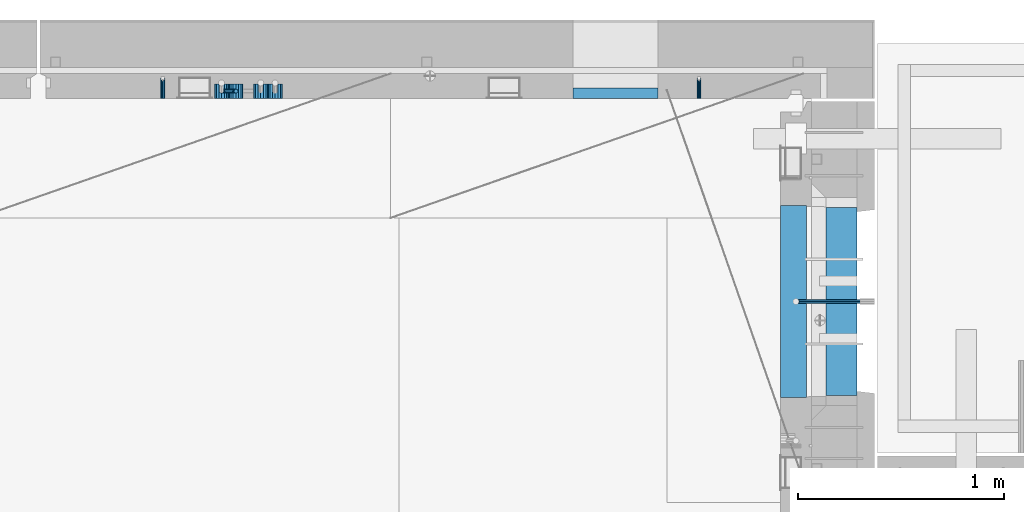
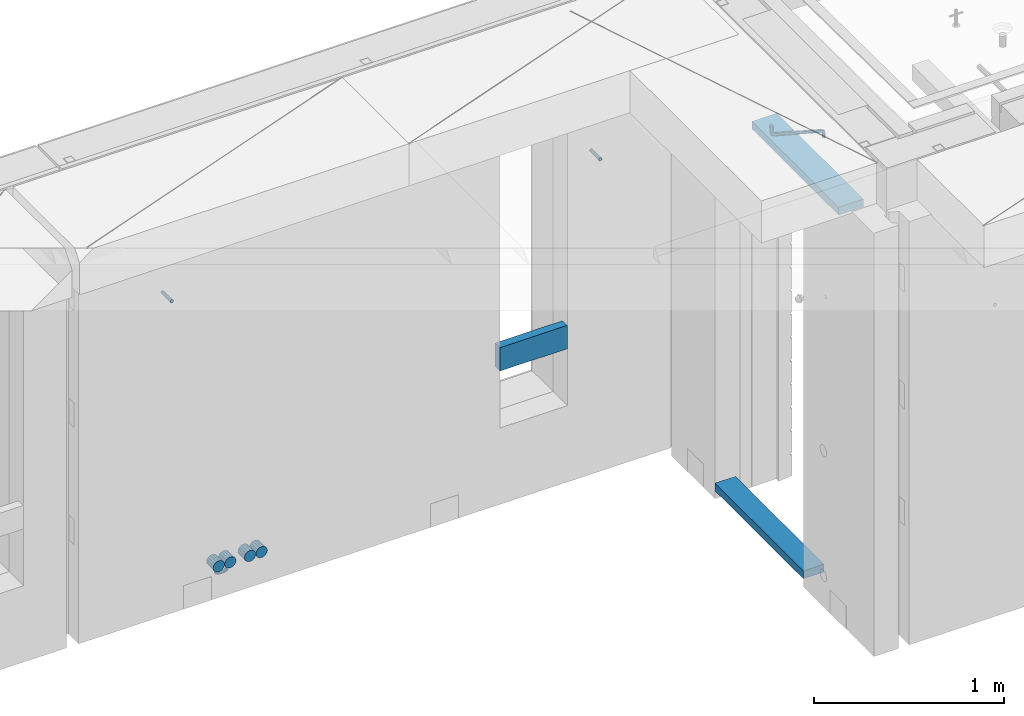
# One storey, part 159 of 334: 11 beams, 4 elements without a shape of their own.
"""IFC2X3 building model written with IfcOpenShell, lengths in millimetres."""

from ifc_helpers import new_model, si_unit, frame, origin_with_axes, place, context, subcontext, project, spatial, faceted_brep, material, type_object, element, aggregate, save


model = new_model("IFC2X3")

# Units and contexts
model_context = context("Model", 3, precision=1e-05, world=origin_with_axes())
body_context = subcontext(model_context, "Body", "Model", "MODEL_VIEW")
ifc_project = project(units=[si_unit("LENGTHUNIT", "METRE", prefix="MILLI"), si_unit("AREAUNIT", "SQUARE_METRE"), si_unit("VOLUMEUNIT", "CUBIC_METRE"), si_unit("MASSUNIT", "GRAM", prefix="KILO"), si_unit("TIMEUNIT", "SECOND"), si_unit("PLANEANGLEUNIT", "RADIAN"), si_unit("SOLIDANGLEUNIT", "STERADIAN"), si_unit("THERMODYNAMICTEMPERATUREUNIT", "DEGREE_CELSIUS"), si_unit("LUMINOUSINTENSITYUNIT", "LUMEN")], contexts=[model_context])

# Site, building, storey
site_placement = place(None, origin_with_axes())
site = spatial("IfcSite", under=ifc_project, at=site_placement, CompositionType="ELEMENT")
building_placement = place(site_placement, origin_with_axes())
building = spatial("IfcBuilding", under=site, at=building_placement, CompositionType="ELEMENT")
storey_placement = place(building_placement, origin_with_axes())
storey = spatial("IfcBuildingStorey", under=building, at=storey_placement, Name="3", CompositionType="ELEMENT", Elevation=0.0)

# Assembly, beam
assembly_1_placement = place(storey_placement, origin_with_axes())
assembly_1 = element("IfcElementAssembly", 1, at=assembly_1_placement, inside=storey, AssemblyPlace="NOTDEFINED", PredefinedType="REINFORCEMENT_UNIT")
ifc_material_1 = material(Name="TIMBER")
beam_type_1 = type_object("IfcBeamType", Name="50X150", PredefinedType="NOTDEFINED")
beam_1_placement = place(assembly_1_placement, frame((31604.9951872276, 21180.0002716511, 90080.0), z_axis=(0.0, 0.0, -1.0), x_axis=(0.0, 1.0, 0.0)))
beam_1 = element("IfcBeam", 2, at=beam_1_placement, type_object=beam_type_1, material=ifc_material_1, ObjectType="50X150", context=body_context, shape_type="Brep", body=[
    faceted_brep([(0.0, 75.0, -25.0), (1.81898940354586e-12, 75.0, 25.0), (909.999618530273, 75.0, 25.0), (909.999618530273, 75.0, -25.0), (1.81898940354586e-12, -75.0000000000009, 25.0), (909.999618530273, -75.0, 25.0), (0.0, -75.0, -25.0), (909.999618530273, -75.0, -25.0)], [[[0, 1, 2, 3]], [[1, 4, 5, 2]], [[4, 6, 7, 5]], [[6, 0, 3, 7]], [[5, 7, 3, 2]], [[6, 4, 1, 0]]]),
])

# Assemblies, beams
assembly_2_placement = place(storey_placement, origin_with_axes())
assembly_2 = element("IfcElementAssembly", 3, at=assembly_2_placement, inside=storey, AssemblyPlace="NOTDEFINED", PredefinedType="REINFORCEMENT_UNIT")
assembly_3_placement = place(assembly_2_placement, origin_with_axes())
assembly_3 = element("IfcElementAssembly", 4, at=assembly_3_placement, Name="Steel Assembly", AssemblyPlace="NOTDEFINED", PredefinedType="RIGID_FRAME")
ifc_material_2 = material(Name="STEEL/Steel_Undefined")
beam_type_2 = type_object("IfcBeamType", PredefinedType="NOTDEFINED")
beam_2_placement = place(assembly_3_placement, frame((30914.9996121022, 22620.0, 89755.0), z_axis=(1.0, 0.0, 0.0), x_axis=(0.0, 1.0, 0.0)))
beam_2 = element("IfcBeam", 5, at=beam_2_placement, type_object=beam_type_2, material=ifc_material_2, Name="M16", context=body_context, shape_type="Brep", body=[
    faceted_brep([(0.0, -8.49999999999272, -1.45519152283669e-11), (0.0, -7.36121593215648, 4.24999999998545), (100.000000000262, -7.36121593215648, 4.24999999998545), (100.000000000262, -8.49999999999272, -1.45519152283669e-11), (0.0, -4.24999999998545, 7.36121593216376), (100.000000000262, -4.24999999998545, 7.36121593216376), (0.0, 1.45519152283669e-11, 8.49999999998545), (100.000000000262, 1.45519152283669e-11, 8.49999999998545), (0.0, 4.25000000001455, 7.36121593216376), (100.000000000262, 4.25000000001455, 7.36121593216376), (0.0, 7.36121593217104, 4.24999999998545), (100.000000000262, 7.36121593217104, 4.24999999998545), (0.0, 8.50000000000728, 0.0), (100.000000000262, 8.50000000000728, 0.0), (0.0, 7.36121593217104, -4.25000000001455), (100.000000000262, 7.36121593217104, -4.25000000001455), (0.0, 4.25000000000728, -7.36121593219286), (100.000000000262, 4.25000000000728, -7.36121593219286), (0.0, 7.27595761418343e-12, -8.5), (100.000000000262, 7.27595761418343e-12, -8.5), (0.0, -4.24999999999272, -7.36121593217831), (100.000000000262, -4.24999999999272, -7.36121593217831), (0.0, -7.36121593215648, -4.25), (100.000000000262, -7.36121593215648, -4.25), (0.0, -10.4999999999927, -1.45519152283669e-11), (0.0, -9.09326673972828, -5.25000000001455), (100.000000000262, -9.09326673972828, -5.25000000001455), (100.000000000262, -10.4999999999927, -1.45519152283669e-11), (0.0, -5.24999999998545, -9.09326673974283), (100.000000000262, -5.24999999998545, -9.09326673974283), (0.0, 7.27595761418343e-12, -10.5), (100.000000000262, 7.27595761418343e-12, -10.5), (0.0, 5.25000000001455, -9.09326673975738), (100.000000000262, 5.25000000001455, -9.09326673975738), (0.0, 9.09326673975011, -5.25000000001455), (100.000000000262, 9.09326673975011, -5.25000000001455), (0.0, 10.5000000000073, -1.45519152283669e-11), (100.000000000262, 10.5000000000073, -1.45519152283669e-11), (0.0, 9.09326673975011, 5.25), (100.000000000262, 9.09326673975011, 5.25), (0.0, 5.25000000000728, 9.09326673972828), (100.000000000262, 5.25000000000728, 9.09326673972828), (0.0, 1.45519152283669e-11, 10.4999999999854), (100.000000000262, 1.45519152283669e-11, 10.4999999999854), (0.0, -5.24999999999272, 9.09326673972828), (100.000000000262, -5.24999999999272, 9.09326673972828), (0.0, -9.09326673972828, 5.24999999998545), (100.000000000262, -9.09326673972828, 5.24999999998545)], [[[0, 1, 2, 3]], [[1, 4, 5, 2]], [[4, 6, 7, 5]], [[6, 8, 9, 7]], [[8, 10, 11, 9]], [[10, 12, 13, 11]], [[12, 14, 15, 13]], [[14, 16, 17, 15]], [[16, 18, 19, 17]], [[18, 20, 21, 19]], [[20, 22, 23, 21]], [[22, 0, 3, 23]], [[24, 25, 26, 27]], [[25, 28, 29, 26]], [[28, 30, 31, 29]], [[30, 32, 33, 31]], [[32, 34, 35, 33]], [[34, 36, 37, 35]], [[36, 38, 39, 37]], [[38, 40, 41, 39]], [[40, 42, 43, 41]], [[42, 44, 45, 43]], [[44, 46, 47, 45]], [[46, 24, 27, 47]], [[29, 31, 33, 35, 37, 39, 41, 43, 45, 47, 27, 26], [5, 7, 9, 11, 13, 15, 17, 19, 21, 23, 3, 2]], [[46, 44, 42, 40, 38, 36, 34, 32, 30, 28, 25, 24], [22, 20, 18, 16, 14, 12, 10, 8, 6, 4, 1, 0]]]),
])
aggregate(assembly_3, [beam_2])
assembly_4_placement = place(assembly_2_placement, origin_with_axes())
assembly_4 = element("IfcElementAssembly", 6, at=assembly_4_placement, Name="Steel Assembly", AssemblyPlace="NOTDEFINED", PredefinedType="RIGID_FRAME")
beam_3_placement = place(assembly_4_placement, frame((28314.9960018609, 22620.0, 89755.0), z_axis=(-1.0, 3.00000001838171e-08, 0.0), x_axis=(0.0, 1.0, 0.0)))
beam_3 = element("IfcBeam", 7, at=beam_3_placement, type_object=beam_type_2, material=ifc_material_2, Name="M16", context=body_context, shape_type="Brep", body=[
    faceted_brep([(0.0, -8.49999999999272, -1.45519152283669e-11), (0.0, -7.36121593215648, 4.24999999998545), (100.000000000262, -7.36121593215648, 4.24999999998545), (100.000000000262, -8.49999999999272, -1.45519152283669e-11), (0.0, -4.24999999998545, 7.36121593216376), (100.000000000262, -4.24999999998545, 7.36121593216376), (0.0, 1.45519152283669e-11, 8.49999999998545), (100.000000000262, 1.45519152283669e-11, 8.49999999998545), (0.0, 4.25000000001455, 7.36121593216376), (100.000000000262, 4.25000000001455, 7.36121593216376), (0.0, 7.36121593217104, 4.24999999998545), (100.000000000262, 7.36121593217104, 4.24999999998545), (0.0, 8.50000000000728, 0.0), (100.000000000262, 8.50000000000728, 0.0), (0.0, 7.36121593217104, -4.25000000001455), (100.000000000262, 7.36121593217104, -4.25000000001455), (0.0, 4.25000000000728, -7.36121593219286), (100.000000000262, 4.25000000000728, -7.36121593219286), (0.0, 7.27595761418343e-12, -8.5), (100.000000000262, 7.27595761418343e-12, -8.5), (0.0, -4.24999999999272, -7.36121593217831), (100.000000000262, -4.24999999999272, -7.36121593217831), (0.0, -7.36121593215648, -4.25), (100.000000000262, -7.36121593215648, -4.25), (0.0, -10.4999999999927, -1.45519152283669e-11), (0.0, -9.09326673972828, -5.25000000001455), (100.000000000262, -9.09326673972828, -5.25000000001455), (100.000000000262, -10.4999999999927, -1.45519152283669e-11), (0.0, -5.24999999998545, -9.09326673974283), (100.000000000262, -5.24999999998545, -9.09326673974283), (0.0, 7.27595761418343e-12, -10.5), (100.000000000262, 7.27595761418343e-12, -10.5), (0.0, 5.25000000001455, -9.09326673975738), (100.000000000262, 5.25000000001455, -9.09326673975738), (0.0, 9.09326673975011, -5.25000000001455), (100.000000000262, 9.09326673975011, -5.25000000001455), (0.0, 10.5000000000073, -1.45519152283669e-11), (100.000000000262, 10.5000000000073, -1.45519152283669e-11), (0.0, 9.09326673975011, 5.25), (100.000000000262, 9.09326673975011, 5.25), (0.0, 5.25000000000728, 9.09326673972828), (100.000000000262, 5.25000000000728, 9.09326673972828), (0.0, 1.45519152283669e-11, 10.4999999999854), (100.000000000262, 1.45519152283669e-11, 10.4999999999854), (0.0, -5.24999999999272, 9.09326673972828), (100.000000000262, -5.24999999999272, 9.09326673972828), (0.0, -9.09326673972828, 5.24999999998545), (100.000000000262, -9.09326673972828, 5.24999999998545)], [[[0, 1, 2, 3]], [[1, 4, 5, 2]], [[4, 6, 7, 5]], [[6, 8, 9, 7]], [[8, 10, 11, 9]], [[10, 12, 13, 11]], [[12, 14, 15, 13]], [[14, 16, 17, 15]], [[16, 18, 19, 17]], [[18, 20, 21, 19]], [[20, 22, 23, 21]], [[22, 0, 3, 23]], [[24, 25, 26, 27]], [[25, 28, 29, 26]], [[28, 30, 31, 29]], [[30, 32, 33, 31]], [[32, 34, 35, 33]], [[34, 36, 37, 35]], [[36, 38, 39, 37]], [[38, 40, 41, 39]], [[40, 42, 43, 41]], [[42, 44, 45, 43]], [[44, 46, 47, 45]], [[46, 24, 27, 47]], [[29, 31, 33, 35, 37, 39, 41, 43, 45, 47, 27, 26], [5, 7, 9, 11, 13, 15, 17, 19, 21, 23, 3, 2]], [[46, 44, 42, 40, 38, 36, 34, 32, 30, 28, 25, 24], [22, 20, 18, 16, 14, 12, 10, 8, 6, 4, 1, 0]]]),
])
aggregate(assembly_4, [beam_3])

# Beam
ifc_material_3 = material()
beam_type_3 = type_object("IfcBeamType", Name="D20", PredefinedType="NOTDEFINED")
beam_4_placement = place(assembly_1_placement, frame((31702.0651872276, 21635.0000000039, 90220.28), z_axis=(-0.999209485784166, -0.00020572799995638, -0.0397537569914116), x_axis=(-0.0397537569985676, 6.39999925638301e-08, 0.999209506962626)))
beam_4 = element("IfcBeam", 8, at=beam_4_placement, type_object=beam_type_3, material=ifc_material_3, Name="JM20", ObjectType="D20", context=body_context, shape_type="Brep", body=[
    faceted_brep([(0.0, -10.0, 0.0), (-4.19531716033816e-08, -7.07106781186667, -7.07106781187031), (26.3851730625611, -7.07106780271351, -7.07106779974674), (26.3851730660535, -9.99999999077045, 1.18243406177498e-08), (0.0, 0.0, -10.0), (26.3851730589668, 9.14587872102857e-09, -9.99999998788189), (4.196772351861e-08, 7.07106781186303, -7.07106781186667), (26.3851730576571, 7.07106782101255, -7.0710677997472), (0.0, 10.0, 0.0), (26.3851730593888, 10.0000000091495, 1.21176526590716e-08), (4.196772351861e-08, 7.07106781185939, 7.07106781185939), (26.3851730631723, 7.07106782101619, 7.07106782398387), (0.0, 0.0, 10.0), (26.3851730667375, 9.15315467864275e-09, 10.0000000121181), (-4.19531716033816e-08, -7.07106781187031, 7.07106781185939), (26.3851730680617, -7.07106780271351, 7.07106782398296), (38.6387990555377, 0.00053833780111745, -7.38336449283906), (37.4430586178205, -7.07058200552274, -4.70977034770021), (34.5550974405633, -9.99964106806146, 1.74460312923975), (31.6666440137633, -7.07083577596131, 8.19887149183023), (30.4697151806322, 0.000179452214069897, 10.8722118684241), (31.6654556183639, 7.07129979554884, 8.19861772327886), (34.5534167956066, 10.0003588580803, 1.74424424634026), (37.4418702223775, 7.07155356597286, -4.71002411625204), (46.5698109210789, 7.07292605872499, 1.96124086770624), (48.7548734831362, 0.00205940803425619, 0.0100898832683924), (41.2967727296491, 10.0013728005906, 6.67270684289633), (36.0246331664675, 7.07195524891722, 11.3845749391899), (33.8417400848848, 0.000686475628754124, 13.3366967298962), (36.0268026468402, -7.07018017507653, 11.385545745416), (41.2998408382991, -9.99862691692761, 6.67407977023777), (46.5719804015243, -7.06920936526149, 1.96221167398289), (52.1766955363273, 7.07494587836845, 11.77897587077), (54.9687243336812, 0.00429788071051007, 10.8906314292522), (45.4389138642146, 10.0028649622, 13.9256551011317), (38.7022804405424, 7.07291984242329, 16.0731735411446), (35.9130237601494, 0.00143263318750542, 16.9635440140905), (38.7050525575032, -7.06921536447044, 16.0751995724927), (45.4428342298197, -9.99713444846202, 13.9285203429881), (52.1794676532882, -7.06718932852891, 11.7810019021831), (142.166420299589, -7.00909836739083, 294.143799597011), (135.429786872017, -9.93904348683645, 296.291318034092), (144.955676979953, 0.0623888418631395, 293.253429124143), (142.163648182657, 7.13303683951744, 294.141773565681), (135.425866510661, 10.0609559233271, 296.288452795829), (128.689233087061, 7.13101080351771, 298.435971235634), (125.899976406712, 0.0595235942673753, 299.326341708503), (128.692005203993, -7.01112440339057, 298.437997266966), (147.068569920637, 0.0631443010061048, 296.926548661886), (144.897857494318, -7.00812174957537, 298.892215917644), (139.655137467547, -9.93753272500544, 303.636800386314), (134.411524128242, -7.00907940566321, 308.380988833921), (132.238655054738, 0.0617899707685865, 310.345700010335), (134.409367481101, 7.13305602133914, 308.38003275464), (139.652087507944, 10.0624669967765, 303.63544828606), (144.895700847192, 7.13401367743427, 298.891259838389), (149.349355837621, 7.13466950711154, 302.082919188319), (150.512901837996, 0.0636515012993186, 299.394888529177), (146.541460642286, 10.0634815017911, 308.572636332), (143.734043175544, 7.13442914049301, 315.062451673432), (142.571650514263, 0.0633115715718304, 317.750719402909), (143.735196514695, -7.0077064342513, 315.062688743805), (146.543091710148, -9.93651842893087, 308.572971600169), (149.350509176773, -7.0074660676255, 302.083156258706), (154.724909358454, 7.13488656737172, 303.143653317829), (154.670204234542, 0.063819369621342, 300.215230568659), (154.856921558763, 10.0638172729959, 310.213489346082), (154.988909878753, 7.13488360238989, 317.283324591871), (155.043557350815, 0.0638151764978829, 320.211745451903), (154.988852227005, -7.00725202125614, 317.28332270274), (154.856840031658, -9.93618272723688, 310.213486674455), (154.724851706691, -7.00724905626703, 303.143651428684), (199.544700311235, -7.00743165723543, 302.30682413155), (199.676688632229, -9.93636532781238, 309.37665937721), (199.490052838737, 0.0636367686238373, 299.378403271518), (199.544757962984, 7.13470396637786, 302.306826020583), (199.676770164122, 10.0636346720203, 309.376662048705), (199.808758485131, 7.13470100144696, 316.446497294365), (199.863405957614, 0.0636325755804137, 319.374918154397), (199.808700833368, -7.00743462216269, 316.446495405334)], [[[0, 1, 2, 3]], [[1, 4, 5, 2]], [[4, 6, 7, 5]], [[6, 8, 9, 7]], [[8, 10, 11, 9]], [[10, 12, 13, 11]], [[12, 14, 15, 13]], [[14, 0, 3, 15]], [[14, 12, 10, 8, 6, 4, 1, 0]], [[2, 5, 16, 17]], [[3, 2, 17, 18]], [[15, 3, 18, 19]], [[13, 15, 19, 20]], [[11, 13, 20, 21]], [[9, 11, 21, 22]], [[7, 9, 22, 23]], [[5, 7, 23, 16]], [[23, 24, 25, 16]], [[22, 26, 24, 23]], [[21, 27, 26, 22]], [[20, 28, 27, 21]], [[19, 29, 28, 20]], [[18, 30, 29, 19]], [[17, 31, 30, 18]], [[16, 25, 31, 17]], [[24, 32, 33, 25]], [[26, 34, 32, 24]], [[27, 35, 34, 26]], [[28, 36, 35, 27]], [[29, 37, 36, 28]], [[30, 38, 37, 29]], [[31, 39, 38, 30]], [[25, 33, 39, 31]], [[38, 39, 40, 41]], [[39, 33, 42, 40]], [[33, 32, 43, 42]], [[32, 34, 44, 43]], [[34, 35, 45, 44]], [[35, 36, 46, 45]], [[36, 37, 47, 46]], [[37, 38, 41, 47]], [[40, 42, 48, 49]], [[41, 40, 49, 50]], [[47, 41, 50, 51]], [[46, 47, 51, 52]], [[45, 46, 52, 53]], [[44, 45, 53, 54]], [[43, 44, 54, 55]], [[42, 43, 55, 48]], [[55, 56, 57, 48]], [[54, 58, 56, 55]], [[53, 59, 58, 54]], [[52, 60, 59, 53]], [[51, 61, 60, 52]], [[50, 62, 61, 51]], [[49, 63, 62, 50]], [[48, 57, 63, 49]], [[56, 64, 65, 57]], [[58, 66, 64, 56]], [[59, 67, 66, 58]], [[60, 68, 67, 59]], [[61, 69, 68, 60]], [[62, 70, 69, 61]], [[63, 71, 70, 62]], [[57, 65, 71, 63]], [[70, 71, 72, 73]], [[71, 65, 74, 72]], [[65, 64, 75, 74]], [[64, 66, 76, 75]], [[66, 67, 77, 76]], [[67, 68, 78, 77]], [[68, 69, 79, 78]], [[69, 70, 73, 79]], [[74, 75, 76, 77, 78, 79, 73, 72]]]),
])

beam_5_placement = place(assembly_2_placement, frame((28600.0, 22655.0000005921, 87920.0), z_axis=(0.000207344999896057, 0.999999978504025, 0.0), x_axis=(0.0, 0.0, -1.0)))
beam_5 = element("IfcBeam", 9, at=beam_5_placement, type_object=beam_type_3, material=ifc_material_3, Name="JM20", ObjectType="D20", context=body_context, shape_type="Brep", body=[
    faceted_brep([(0.0, -10.0, 0.0), (-4.19531716033816e-08, -7.07106781186667, -7.07106781187031), (15.0, -7.07106781186303, -7.07106781186303), (15.0, -10.0, 0.0), (0.0, 0.0, -10.0), (15.0, 0.0, -10.0), (4.196772351861e-08, 7.07106781186303, -7.07106781186667), (15.0, 7.07106781186303, -7.07106781186303), (0.0, 10.0, 0.0), (15.0, 10.0, 0.0), (4.196772351861e-08, 7.07106781185939, 7.07106781185939), (15.0, 7.07106781186303, 7.07106781186303), (0.0, 0.0, 10.0), (15.0, 0.0, 10.0), (-4.19531716033816e-08, -7.07106781187031, 7.07106781185939), (15.0, -7.07106781186303, 7.07106781186303), (26.4805029249983, 7.71638602031089, -4.48664359282702e-05), (25.3600699192612, 5.00995527536361, -7.07100705464109), (22.6542637537787, -1.5230460533603, -9.99968429821456), (19.9481089831243, -8.05567439054357, -7.07049718768394), (18.826834370062, -10.7612046541835, 0.00067619437322719), (19.9472673757409, -8.05477390922533, 7.07163838257111), (22.6530735411652, -1.52177258047232, 10.0003156261519), (25.3592283118487, 5.01085575670004, 7.07112851561396), (34.1416172347817, -0.856916444474336, 7.07197867868672), (36.213203398147, 1.21320358659068, 0.000785173426265828), (29.141402548732, -5.85652387542723, 10.0012144823486), (24.1416172883619, -10.8569164797627, 7.07258597800683), (22.0710678501491, -12.9289320870121, 0.00164402434893418), (24.1426540134416, -10.8588120558743, -7.06954948090424), (29.1428686994623, -5.8592046249214, -9.99878528456611), (34.1426539599051, -0.858812020647747, -7.07015678022435), (40.0100668298401, -9.63902468957167, 7.07343309580028), (42.7163859636639, -8.51949674357456, 0.00228483768296428), (33.4771117462369, -12.3444560058379, 10.0025597629719), (26.9444371984719, -15.0509857193756, 7.07382216348924), (24.2387953379803, -16.1731654308933, 0.00283506249979837), (26.9451144717314, -15.0536374847834, -7.0683131956248), (33.47806955532, -12.3482061684881, -9.99743986281101), (40.0107441031432, -9.64167645503403, -7.06870226332103), (42.0710678126343, -19.9985334195844, 7.07521456002723), (45.0000000007858, -19.9999995702492, 0.00414690004981821), (35.0000000006694, -19.9979261199842, 10.0041466852272), (27.9289321887481, -19.9985334194498, 7.07521455996903), (25.0, -19.9999995700782, 0.00414690009347396), (27.928932188719, -20.0014657206229, -7.06692075997853), (35.0000000006548, -20.0020730201395, -9.99585288517846), (42.0710678125906, -20.001465720783, -7.0669207599276), (27.928932188137, -50.001465075733, -7.06070040962368), (24.9999999998254, -49.9999989249554, 0.010367250208219), (35.0, -50.0020723751913, -9.98963253479451), (42.071067811863, -50.001465075733, -7.06070040962368), (45.0, -49.999998925141, 0.0103672502445988), (42.071067811863, -49.9985327745489, 7.08143491011288), (35.0, -49.9979254750906, 10.010367035291), (27.928932188137, -49.9985327745489, 7.08143491011288), (42.7163859754073, -61.4805016490391, 0.0127476751804352), (40.0104054746334, -60.3611140008325, -7.05855238820368), (33.4775906501454, -57.6557408577646, -9.98804558495613), (26.944775825672, -54.9491531157582, -7.05967453130143), (24.2387953248981, -53.8268331663385, 0.0111607251892565), (26.9447758256429, -54.9462208145851, 7.08246078858792), (33.4775906501163, -57.6515939576748, 10.0119539853549), (40.0104054746189, -60.3581816996521, 7.08358293168567), (34.1421356237697, -69.1406679865104, 7.08540393637668), (36.213203435691, -71.213201904422, 0.014765702006116), (29.1421356236242, -64.1400607945761, 10.0132993365623), (24.1421356235078, -59.1406682015404, 7.0833304863263), (22.0710678116011, -57.071066584791, 0.011833400807518), (24.1421356235223, -59.1436005027172, -7.05880483355577), (29.1421356236242, -64.1442076946769, -9.98670023374871), (34.1421356237552, -69.1436002877017, -7.05673138350539), (25.3596491481148, -75.008937711249, 7.08662069281127), (26.4805029710988, -77.7163843043891, 0.0161141044009128), (22.6536686472245, -68.475515727856, 10.014198271514), (19.9476881463488, -61.943308343376, 7.08391159978055), (18.8268343233794, -59.2387940514018, 0.0122828682870022), (19.9476881463343, -61.94624064456, -7.05822372010152), (22.6536686471809, -68.4796626279458, -9.98580129879701), (25.3596491480712, -75.0118700124258, -7.05551462707081), (15.0000000001164, -77.0696000043099, 7.08704796086386), (15.0000000001746, -79.9999982800764, 0.0165876003811718), (14.9999999999418, -69.9979250449542, 10.0145139355009), (14.9999999997963, -62.9274646845297, 7.08411565970164), (15.0, -59.9999987101801, 0.0124407002949738), (14.9999999997672, -62.9303969856919, -7.05801966018043), (14.9999999998836, -70.0020719450404, -9.98548563481017), (15.0000000000582, -77.0725323054685, -7.05508735901822), (0.0, -62.9303969859466, -7.05801966011495), (0.0, -59.9999987101801, 0.0124407002949738), (0.0, -70.0020719452732, -9.98548563470104), (0.0, -77.0725323056759, -7.0550873589309), (0.0, -79.9999982802619, 0.0165876003884478), (0.0, -77.0696000044954, 7.08704796080565), (0.0, -69.9979250451725, 10.0145139353845), (0.0, -62.9274646847625, 7.0841156596216)], [[[0, 1, 2, 3]], [[1, 4, 5, 2]], [[4, 6, 7, 5]], [[6, 8, 9, 7]], [[8, 10, 11, 9]], [[10, 12, 13, 11]], [[12, 14, 15, 13]], [[14, 0, 3, 15]], [[14, 12, 10, 8, 6, 4, 1, 0]], [[7, 9, 16, 17]], [[5, 7, 17, 18]], [[2, 5, 18, 19]], [[3, 2, 19, 20]], [[15, 3, 20, 21]], [[13, 15, 21, 22]], [[11, 13, 22, 23]], [[9, 11, 23, 16]], [[23, 24, 25, 16]], [[22, 26, 24, 23]], [[21, 27, 26, 22]], [[20, 28, 27, 21]], [[19, 29, 28, 20]], [[18, 30, 29, 19]], [[17, 31, 30, 18]], [[16, 25, 31, 17]], [[24, 32, 33, 25]], [[26, 34, 32, 24]], [[27, 35, 34, 26]], [[28, 36, 35, 27]], [[29, 37, 36, 28]], [[30, 38, 37, 29]], [[31, 39, 38, 30]], [[25, 33, 39, 31]], [[32, 40, 41, 33]], [[34, 42, 40, 32]], [[35, 43, 42, 34]], [[36, 44, 43, 35]], [[37, 45, 44, 36]], [[38, 46, 45, 37]], [[39, 47, 46, 38]], [[33, 41, 47, 39]], [[44, 45, 48, 49]], [[45, 46, 50, 48]], [[46, 47, 51, 50]], [[47, 41, 52, 51]], [[41, 40, 53, 52]], [[40, 42, 54, 53]], [[42, 43, 55, 54]], [[43, 44, 49, 55]], [[51, 52, 56, 57]], [[50, 51, 57, 58]], [[48, 50, 58, 59]], [[49, 48, 59, 60]], [[55, 49, 60, 61]], [[54, 55, 61, 62]], [[53, 54, 62, 63]], [[52, 53, 63, 56]], [[63, 64, 65, 56]], [[62, 66, 64, 63]], [[61, 67, 66, 62]], [[60, 68, 67, 61]], [[59, 69, 68, 60]], [[58, 70, 69, 59]], [[57, 71, 70, 58]], [[56, 65, 71, 57]], [[64, 72, 73, 65]], [[66, 74, 72, 64]], [[67, 75, 74, 66]], [[68, 76, 75, 67]], [[69, 77, 76, 68]], [[70, 78, 77, 69]], [[71, 79, 78, 70]], [[65, 73, 79, 71]], [[72, 80, 81, 73]], [[74, 82, 80, 72]], [[75, 83, 82, 74]], [[76, 84, 83, 75]], [[77, 85, 84, 76]], [[78, 86, 85, 77]], [[79, 87, 86, 78]], [[73, 81, 87, 79]], [[84, 85, 88, 89]], [[85, 86, 90, 88]], [[86, 87, 91, 90]], [[87, 81, 92, 91]], [[81, 80, 93, 92]], [[80, 82, 94, 93]], [[82, 83, 95, 94]], [[83, 84, 89, 95]], [[90, 91, 92, 93, 94, 95, 89, 88]]]),
])

beam_type_4 = type_object("IfcBeamType", Name="D70", PredefinedType="NOTDEFINED")
beam_6_placement = place(assembly_2_placement, frame((28600.0, 22619.9999977209, 87955.0), z_axis=(0.0, 0.0, 1.0), x_axis=(0.0, 1.0, 0.0)))
beam_6 = element("IfcBeam", 10, at=beam_6_placement, type_object=beam_type_4, material=ifc_material_3, ObjectType="D70", context=body_context, shape_type="Brep", body=[
    faceted_brep([(0.0, -35.0, 0.0), (0.0, -32.3357836378964, -13.3939201327739), (70.0, -32.3357836378964, -13.3939201327739), (70.0, -35.0, 0.0), (0.0, -24.7487373415279, -24.7487373415352), (70.0, -24.7487373415279, -24.7487373415352), (0.0, -13.3939201327776, -32.3357836379), (70.0, -13.3939201327776, -32.3357836379), (0.0, 0.0, -35.0), (70.0, 0.0, -35.0), (0.0, 13.3939201327776, -32.3357836379), (70.0, 13.3939201327776, -32.3357836379), (0.0, 24.7487373415279, -24.7487373415352), (70.0, 24.7487373415279, -24.7487373415352), (0.0, 32.3357836378964, -13.3939201327739), (70.0, 32.3357836378964, -13.3939201327739), (0.0, 35.0, 0.0), (70.0, 35.0, 0.0), (0.0, 32.3357836378964, 13.3939201327739), (70.0, 32.3357836378964, 13.3939201327739), (0.0, 24.7487373415279, 24.7487373415352), (70.0, 24.7487373415279, 24.7487373415352), (0.0, 13.3939201327776, 32.3357836379), (70.0, 13.3939201327776, 32.3357836379), (0.0, 0.0, 35.0), (70.0, 0.0, 35.0), (0.0, -13.3939201327776, 32.3357836379), (70.0, -13.3939201327776, 32.3357836379), (0.0, -24.7487373415279, 24.7487373415352), (70.0, -24.7487373415279, 24.7487373415352), (0.0, -32.3357836378964, 13.3939201327739), (70.0, -32.3357836378964, 13.3939201327739)], [[[0, 1, 2, 3]], [[1, 4, 5, 2]], [[4, 6, 7, 5]], [[6, 8, 9, 7]], [[8, 10, 11, 9]], [[10, 12, 13, 11]], [[12, 14, 15, 13]], [[14, 16, 17, 15]], [[16, 18, 19, 17]], [[18, 20, 21, 19]], [[20, 22, 23, 21]], [[22, 24, 25, 23]], [[24, 26, 27, 25]], [[26, 28, 29, 27]], [[28, 30, 31, 29]], [[30, 0, 3, 31]], [[5, 7, 9, 11, 13, 15, 17, 19, 21, 23, 25, 27, 29, 31, 3, 2]], [[30, 28, 26, 24, 22, 20, 18, 16, 14, 12, 10, 8, 6, 4, 1, 0]]]),
])

beam_7_placement = place(assembly_2_placement, frame((28670.0, 22619.9999977209, 87955.0), z_axis=(0.0, 0.0, 1.0), x_axis=(0.0, 1.0, 0.0)))
beam_7 = element("IfcBeam", 11, at=beam_7_placement, type_object=beam_type_4, material=ifc_material_3, ObjectType="D70", context=body_context, shape_type="Brep", body=[
    faceted_brep([(0.0, -35.0, 0.0), (0.0, -32.3357836378964, -13.3939201327739), (70.0, -32.3357836378964, -13.3939201327739), (70.0, -35.0, 0.0), (0.0, -24.7487373415279, -24.7487373415352), (70.0, -24.7487373415279, -24.7487373415352), (0.0, -13.3939201327776, -32.3357836379), (70.0, -13.3939201327776, -32.3357836379), (0.0, 0.0, -35.0), (70.0, 0.0, -35.0), (0.0, 13.3939201327776, -32.3357836379), (70.0, 13.3939201327776, -32.3357836379), (0.0, 24.7487373415279, -24.7487373415352), (70.0, 24.7487373415279, -24.7487373415352), (0.0, 32.3357836378964, -13.3939201327739), (70.0, 32.3357836378964, -13.3939201327739), (0.0, 35.0, 0.0), (70.0, 35.0, 0.0), (0.0, 32.3357836378964, 13.3939201327739), (70.0, 32.3357836378964, 13.3939201327739), (0.0, 24.7487373415279, 24.7487373415352), (70.0, 24.7487373415279, 24.7487373415352), (0.0, 13.3939201327776, 32.3357836379), (70.0, 13.3939201327776, 32.3357836379), (0.0, 0.0, 35.0), (70.0, 0.0, 35.0), (0.0, -13.3939201327776, 32.3357836379), (70.0, -13.3939201327776, 32.3357836379), (0.0, -24.7487373415279, 24.7487373415352), (70.0, -24.7487373415279, 24.7487373415352), (0.0, -32.3357836378964, 13.3939201327739), (70.0, -32.3357836378964, 13.3939201327739)], [[[0, 1, 2, 3]], [[1, 4, 5, 2]], [[4, 6, 7, 5]], [[6, 8, 9, 7]], [[8, 10, 11, 9]], [[10, 12, 13, 11]], [[12, 14, 15, 13]], [[14, 16, 17, 15]], [[16, 18, 19, 17]], [[18, 20, 21, 19]], [[20, 22, 23, 21]], [[22, 24, 25, 23]], [[24, 26, 27, 25]], [[26, 28, 29, 27]], [[28, 30, 31, 29]], [[30, 0, 3, 31]], [[5, 7, 9, 11, 13, 15, 17, 19, 21, 23, 25, 27, 29, 31, 3, 2]], [[30, 28, 26, 24, 22, 20, 18, 16, 14, 12, 10, 8, 6, 4, 1, 0]]]),
])

beam_8_placement = place(assembly_2_placement, frame((28790.0, 22619.9999977209, 87955.0), z_axis=(0.0, 0.0, 1.0), x_axis=(0.0, 1.0, 0.0)))
beam_8 = element("IfcBeam", 12, at=beam_8_placement, type_object=beam_type_4, material=ifc_material_3, ObjectType="D70", context=body_context, shape_type="Brep", body=[
    faceted_brep([(0.0, -35.0, 0.0), (0.0, -32.3357836378964, -13.3939201327739), (70.0, -32.3357836378964, -13.3939201327739), (70.0, -35.0, 0.0), (0.0, -24.7487373415279, -24.7487373415352), (70.0, -24.7487373415279, -24.7487373415352), (0.0, -13.3939201327776, -32.3357836379), (70.0, -13.3939201327776, -32.3357836379), (0.0, 0.0, -35.0), (70.0, 0.0, -35.0), (0.0, 13.3939201327776, -32.3357836379), (70.0, 13.3939201327776, -32.3357836379), (0.0, 24.7487373415279, -24.7487373415352), (70.0, 24.7487373415279, -24.7487373415352), (0.0, 32.3357836378964, -13.3939201327739), (70.0, 32.3357836378964, -13.3939201327739), (0.0, 35.0, 0.0), (70.0, 35.0, 0.0), (0.0, 32.3357836378964, 13.3939201327739), (70.0, 32.3357836378964, 13.3939201327739), (0.0, 24.7487373415279, 24.7487373415352), (70.0, 24.7487373415279, 24.7487373415352), (0.0, 13.3939201327776, 32.3357836379), (70.0, 13.3939201327776, 32.3357836379), (0.0, 0.0, 35.0), (70.0, 0.0, 35.0), (0.0, -13.3939201327776, 32.3357836379), (70.0, -13.3939201327776, 32.3357836379), (0.0, -24.7487373415279, 24.7487373415352), (70.0, -24.7487373415279, 24.7487373415352), (0.0, -32.3357836378964, 13.3939201327739), (70.0, -32.3357836378964, 13.3939201327739)], [[[0, 1, 2, 3]], [[1, 4, 5, 2]], [[4, 6, 7, 5]], [[6, 8, 9, 7]], [[8, 10, 11, 9]], [[10, 12, 13, 11]], [[12, 14, 15, 13]], [[14, 16, 17, 15]], [[16, 18, 19, 17]], [[18, 20, 21, 19]], [[20, 22, 23, 21]], [[22, 24, 25, 23]], [[24, 26, 27, 25]], [[26, 28, 29, 27]], [[28, 30, 31, 29]], [[30, 0, 3, 31]], [[5, 7, 9, 11, 13, 15, 17, 19, 21, 23, 25, 27, 29, 31, 3, 2]], [[30, 28, 26, 24, 22, 20, 18, 16, 14, 12, 10, 8, 6, 4, 1, 0]]]),
])

beam_9_placement = place(assembly_2_placement, frame((28860.0, 22619.9999977209, 87955.0), z_axis=(0.0, 0.0, 1.0), x_axis=(0.0, 1.0, 0.0)))
beam_9 = element("IfcBeam", 13, at=beam_9_placement, type_object=beam_type_4, material=ifc_material_3, ObjectType="D70", context=body_context, shape_type="Brep", body=[
    faceted_brep([(0.0, -35.0, 0.0), (0.0, -32.3357836378964, -13.3939201327739), (70.0, -32.3357836378964, -13.3939201327739), (70.0, -35.0, 0.0), (0.0, -24.7487373415279, -24.7487373415352), (70.0, -24.7487373415279, -24.7487373415352), (0.0, -13.3939201327776, -32.3357836379), (70.0, -13.3939201327776, -32.3357836379), (0.0, 0.0, -35.0), (70.0, 0.0, -35.0), (0.0, 13.3939201327776, -32.3357836379), (70.0, 13.3939201327776, -32.3357836379), (0.0, 24.7487373415279, -24.7487373415352), (70.0, 24.7487373415279, -24.7487373415352), (0.0, 32.3357836378964, -13.3939201327739), (70.0, 32.3357836378964, -13.3939201327739), (0.0, 35.0, 0.0), (70.0, 35.0, 0.0), (0.0, 32.3357836378964, 13.3939201327739), (70.0, 32.3357836378964, 13.3939201327739), (0.0, 24.7487373415279, 24.7487373415352), (70.0, 24.7487373415279, 24.7487373415352), (0.0, 13.3939201327776, 32.3357836379), (70.0, 13.3939201327776, 32.3357836379), (0.0, 0.0, 35.0), (70.0, 0.0, 35.0), (0.0, -13.3939201327776, 32.3357836379), (70.0, -13.3939201327776, 32.3357836379), (0.0, -24.7487373415279, 24.7487373415352), (70.0, -24.7487373415279, 24.7487373415352), (0.0, -32.3357836378964, 13.3939201327739), (70.0, -32.3357836378964, 13.3939201327739)], [[[0, 1, 2, 3]], [[1, 4, 5, 2]], [[4, 6, 7, 5]], [[6, 8, 9, 7]], [[8, 10, 11, 9]], [[10, 12, 13, 11]], [[12, 14, 15, 13]], [[14, 16, 17, 15]], [[16, 18, 19, 17]], [[18, 20, 21, 19]], [[20, 22, 23, 21]], [[22, 24, 25, 23]], [[24, 26, 27, 25]], [[26, 28, 29, 27]], [[28, 30, 31, 29]], [[30, 0, 3, 31]], [[5, 7, 9, 11, 13, 15, 17, 19, 21, 23, 25, 27, 29, 31, 3, 2]], [[30, 28, 26, 24, 22, 20, 18, 16, 14, 12, 10, 8, 6, 4, 1, 0]]]),
])

ifc_material_4 = material(Name="TIMBER/PUU")
beam_type_5 = type_object("IfcBeamType", PredefinedType="NOTDEFINED")
beam_10_placement = place(assembly_1_placement, frame((31372.4951872276, 22100.0000381475, 87830.0), z_axis=(0.0, 0.0, 1.0), x_axis=(0.0, -1.0, 0.0)))
beam_10 = element("IfcBeam", 14, at=beam_10_placement, type_object=beam_type_5, material=ifc_material_4, context=body_context, shape_type="Brep", body=[
    faceted_brep([(0.0, 62.5, -25.0), (0.0, 62.5, 25.0), (930.0, 62.5, 25.0), (930.0, 62.5, -25.0), (0.0, -62.5, 25.0), (930.0, -62.5, 25.0), (0.0, -62.5, -25.0), (930.0, -62.5, -25.0)], [[[0, 1, 2, 3]], [[1, 4, 5, 2]], [[4, 6, 7, 5]], [[6, 0, 3, 7]], [[5, 7, 3, 2]], [[6, 4, 1, 0]]]),
])

aggregate(assembly_1, [beam_4, beam_10, beam_1])

ifc_material_5 = material(Name="TIMBER/T24")
beam_type_6 = type_object("IfcBeamType", PredefinedType="NOTDEFINED")
beam_11_placement = place(assembly_2_placement, frame((30715.0003035754, 22644.9998418812, 88685.0), z_axis=(0.0, 0.0, 1.0), x_axis=(-1.0, 3.00000001838171e-08, 0.0)))
beam_11 = element("IfcBeam", 15, at=beam_11_placement, type_object=beam_type_6, material=ifc_material_5, context=body_context, shape_type="Brep", body=[
    faceted_brep([(-3.63797880709171e-12, 24.9999999999964, -75.0), (-3.63797880709171e-12, 24.9999999999964, 75.0), (410.0, 25.0, 75.0), (410.0, 25.0, -75.0), (0.0, -25.0000000000073, 75.0), (410.0, -25.0, 75.0), (0.0, -25.0000000000073, -75.0), (410.0, -25.0, -75.0)], [[[0, 1, 2, 3]], [[1, 4, 5, 2]], [[4, 6, 7, 5]], [[6, 0, 3, 7]], [[5, 7, 3, 2]], [[6, 4, 1, 0]]]),
])

aggregate(assembly_2, [beam_5, beam_6, beam_7, beam_8, beam_9, assembly_3, assembly_4, beam_11])

save(model, "model.ifc")
